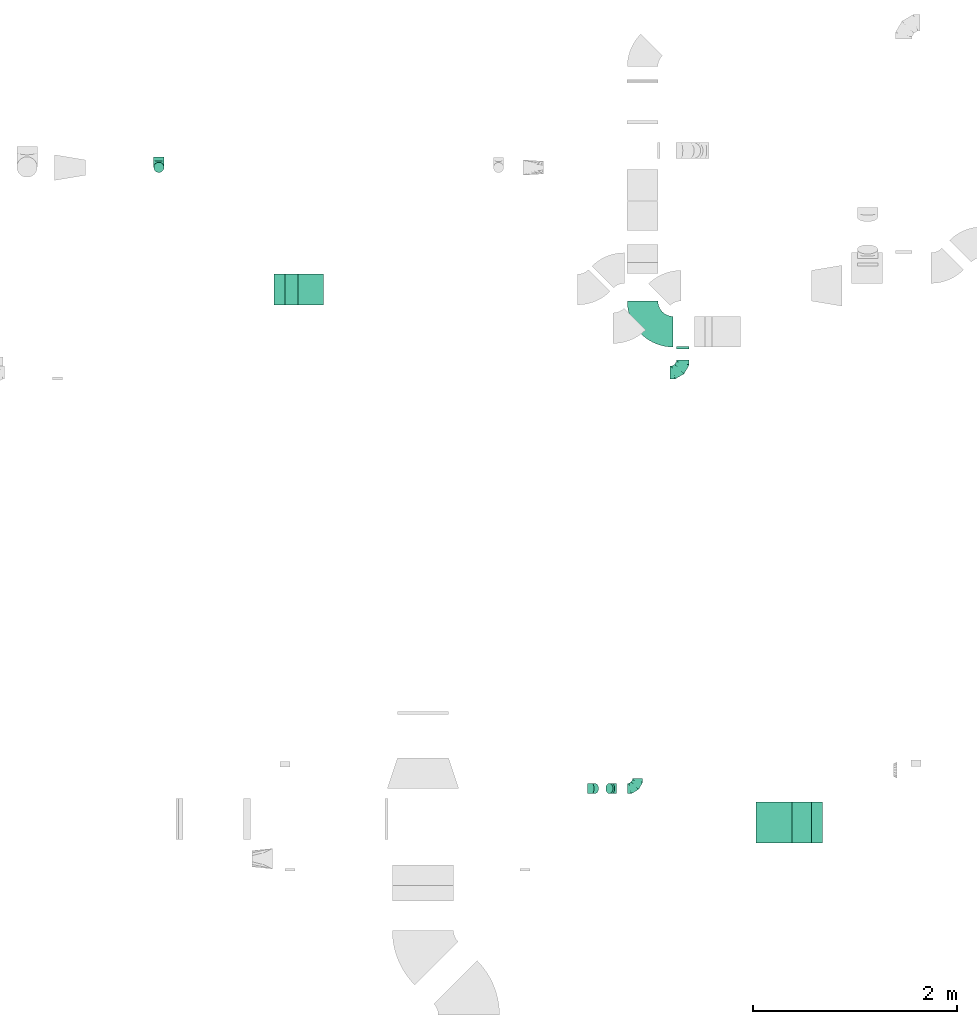
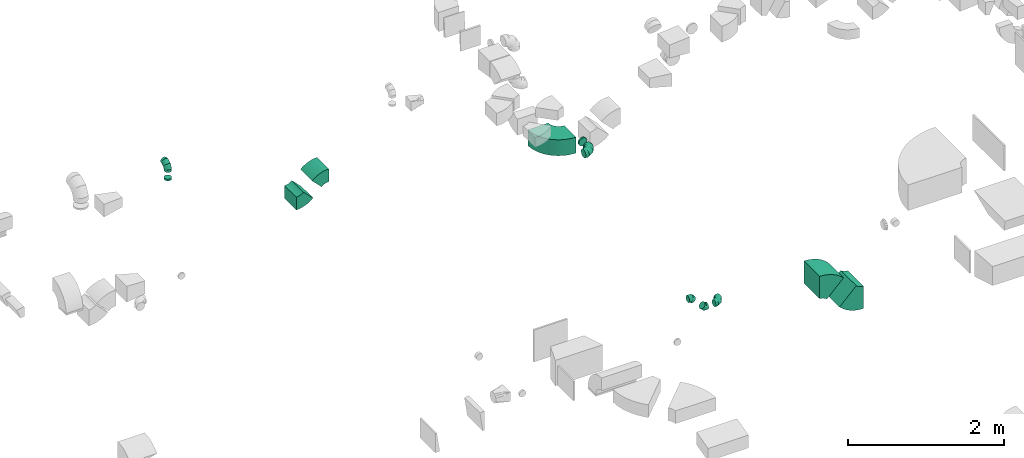
# One storey, part 22 of 44: 12 flow fittings.
"""IFC2X3 building model written with IfcOpenShell, lengths in millimetres."""

from ifc_helpers import new_model, entity, si_unit, converted_unit, derived_unit, direction, frame, frame_2d, origin, place, context, subcontext, project, spatial, polyline, circle_curve, parameter, trimmed, segment, composite_curve, outline, extrude, faceted_brep, source, transform, mapped, material, type_object, type_shapes, element, save


model = new_model("IFC2X3")

# Units and contexts
model_context = context("Model", 3, precision=0.01, world=origin(), true_north=direction((6.12303176911189e-17, 1.0)))
body_context = subcontext(model_context, "Body", "Model", "MODEL_VIEW")
ifc_project = project(units=[si_unit("LENGTHUNIT", "METRE", prefix="MILLI"), si_unit("AREAUNIT", "SQUARE_METRE"), si_unit("VOLUMEUNIT", "CUBIC_METRE"), converted_unit("PLANEANGLEUNIT", "DEGREE", entity("IfcRatioMeasure", 0.0174532925199433), si_unit("PLANEANGLEUNIT", "RADIAN"), dimensions=[0, 0, 0, 0, 0, 0, 0]), si_unit("MASSUNIT", "GRAM", prefix="KILO"), derived_unit("MASSDENSITYUNIT", [(si_unit("MASSUNIT", "GRAM", prefix="KILO"), 1), (si_unit("LENGTHUNIT", "METRE"), -3)]), derived_unit("MOMENTOFINERTIAUNIT", [(si_unit("LENGTHUNIT", "METRE"), 4)]), si_unit("TIMEUNIT", "SECOND"), si_unit("FREQUENCYUNIT", "HERTZ"), si_unit("THERMODYNAMICTEMPERATUREUNIT", "DEGREE_CELSIUS"), derived_unit("THERMALTRANSMITTANCEUNIT", [(si_unit("MASSUNIT", "GRAM", prefix="KILO"), 1), (si_unit("THERMODYNAMICTEMPERATUREUNIT", "KELVIN"), -1), (si_unit("TIMEUNIT", "SECOND"), -3)]), derived_unit("VOLUMETRICFLOWRATEUNIT", [(si_unit("LENGTHUNIT", "METRE"), 3), (si_unit("TIMEUNIT", "SECOND"), -1)]), derived_unit("MASSFLOWRATEUNIT", [(si_unit("MASSUNIT", "GRAM", prefix="KILO"), 1), (si_unit("TIMEUNIT", "SECOND"), -1)]), derived_unit("ROTATIONALFREQUENCYUNIT", [(si_unit("TIMEUNIT", "SECOND"), -1)]), si_unit("ELECTRICCURRENTUNIT", "AMPERE"), si_unit("ELECTRICVOLTAGEUNIT", "VOLT"), si_unit("POWERUNIT", "WATT"), si_unit("FORCEUNIT", "NEWTON", prefix="KILO"), si_unit("ILLUMINANCEUNIT", "LUX"), si_unit("LUMINOUSFLUXUNIT", "LUMEN"), si_unit("LUMINOUSINTENSITYUNIT", "CANDELA"), derived_unit("USERDEFINED", [(si_unit("MASSUNIT", "GRAM", prefix="KILO"), -1), (si_unit("LENGTHUNIT", "METRE"), -2), (si_unit("TIMEUNIT", "SECOND"), 3), (si_unit("LUMINOUSFLUXUNIT", "LUMEN"), 1)]), derived_unit("LINEARVELOCITYUNIT", [(si_unit("LENGTHUNIT", "METRE"), 1), (si_unit("TIMEUNIT", "SECOND"), -1)]), si_unit("PRESSUREUNIT", "PASCAL"), derived_unit("USERDEFINED", [(si_unit("LENGTHUNIT", "METRE"), -2), (si_unit("MASSUNIT", "GRAM", prefix="KILO"), 1), (si_unit("TIMEUNIT", "SECOND"), -2)]), derived_unit("LINEARFORCEUNIT", [(si_unit("MASSUNIT", "GRAM", prefix="KILO"), 1), (si_unit("LENGTHUNIT", "METRE"), 1), (si_unit("TIMEUNIT", "SECOND"), -2), (si_unit("LENGTHUNIT", "METRE"), -1)]), derived_unit("PLANARFORCEUNIT", [(si_unit("MASSUNIT", "GRAM", prefix="KILO"), 1), (si_unit("LENGTHUNIT", "METRE"), 1), (si_unit("TIMEUNIT", "SECOND"), -2), (si_unit("LENGTHUNIT", "METRE"), -2)])], contexts=[model_context])

# Site, building, storey
site_placement = place(None, origin())
site = spatial("IfcSite", under=ifc_project, at=site_placement, CompositionType="ELEMENT")
building_placement = place(site_placement, origin())
building = spatial("IfcBuilding", under=site, at=building_placement, CompositionType="ELEMENT")
storey_placement = place(building_placement, frame((0.0, 0.0, 15900.0)))
storey = spatial("IfcBuildingStorey", under=building, at=storey_placement, CompositionType="ELEMENT", Elevation=15900.0)

# Flow fittings
ifc_material = material()
duct_fitting_type_1 = type_object("IfcDuctFittingType", PredefinedType="NOTDEFINED", material=ifc_material)
shared_shape_1 = source(origin(), body_context, "Body", "Brep", [
    faceted_brep([(-100.0, 0.0, -50.0), (-100.0, -12.94, -48.3), (-100.0, -25.0, -43.3), (-100.0, -35.36, -35.36), (-100.0, -43.3, -25.0), (-100.0, -48.3, -12.94), (-100.0, -50.0, 0.0), (-100.0, -48.3, 12.94), (-100.0, -43.3, 25.0), (-100.0, -35.36, 35.36), (-100.0, -25.0, 43.3), (-100.0, -12.94, 48.3), (-100.0, 0.0, 50.0), (-100.0, 12.94, 48.3), (-100.0, 25.0, 43.3), (-100.0, 35.36, 35.36), (-100.0, 43.3, 25.0), (-100.0, 48.3, 12.94), (-100.0, 50.0, 0.0), (-100.0, 48.3, -12.94), (-100.0, 43.3, -25.0), (-100.0, 35.36, -35.36), (-100.0, 25.0, -43.3), (-100.0, 12.94, -48.3), (-76.67, 12.94, 48.3), (-79.9, 25.0, 43.3), (-73.21, 0.0, 50.0), (-82.68, 35.36, 35.36), (-86.15, 48.3, 12.94), (-86.6, 50.0, 0.0), (-84.81, 43.3, 25.0), (-84.81, 43.3, -25.0), (-82.68, 35.36, -35.36), (-86.15, 48.3, -12.94), (-76.67, 12.94, -48.3), (-73.21, 0.0, -50.0), (-79.9, 25.0, -43.3), (-69.74, -12.94, -48.3), (-66.51, -25.0, -43.3), (-63.73, -35.36, -35.36), (-61.6, -43.3, -25.0), (-60.26, -48.3, -12.94), (-59.81, -50.0, 0.0), (-60.26, -48.3, 12.94), (-61.6, -43.3, 25.0), (-63.73, -35.36, 35.36), (-66.51, -25.0, 43.3), (-69.74, -12.94, 48.3), (-36.27, 36.27, 48.3), (-45.1, 45.1, 43.3), (-26.79, 26.79, 50.0), (-52.68, 52.68, 35.36), (-58.49, 58.49, 25.0), (-62.15, 62.15, 12.94), (-63.4, 63.4, 0.0), (-62.15, 62.15, -12.94), (-58.49, 58.49, -25.0), (-52.68, 52.68, -35.36), (-36.27, 36.27, -48.3), (-26.79, 26.79, -50.0), (-45.1, 45.1, -43.3), (-17.32, 17.32, -48.3), (-8.49, 8.49, -43.3), (-0.91, 0.91, -35.36), (4.9, -4.9, -25.0), (8.56, -8.56, -12.94), (9.81, -9.81, 0.0), (8.56, -8.56, 12.94), (4.9, -4.9, 25.0), (-0.91, 0.91, 35.36), (-8.49, 8.49, 43.3), (-17.32, 17.32, 48.3), (-12.94, 76.67, 48.3), (-25.0, 79.9, 43.3), (0.0, 73.21, 50.0), (-35.36, 82.68, 35.36), (-43.3, 84.81, 25.0), (-48.3, 86.15, 12.94), (-50.0, 86.6, 0.0), (-48.3, 86.15, -12.94), (-43.3, 84.81, -25.0), (-35.36, 82.68, -35.36), (-12.94, 76.67, -48.3), (0.0, 73.21, -50.0), (-25.0, 79.9, -43.3), (12.94, 69.74, -48.3), (25.0, 66.51, -43.3), (35.36, 63.73, -35.36), (43.3, 61.6, -25.0), (48.3, 60.26, -12.94), (50.0, 59.81, 0.0), (48.3, 60.26, 12.94), (43.3, 61.6, 25.0), (35.36, 63.73, 35.36), (25.0, 66.51, 43.3), (12.94, 69.74, 48.3), (-12.94, 100.0, -48.3), (-25.0, 100.0, -43.3), (-35.36, 100.0, -35.36), (-43.3, 100.0, -25.0), (-48.3, 100.0, -12.94), (-50.0, 100.0, 0.0), (-48.3, 100.0, 12.94), (-43.3, 100.0, 25.0), (-35.36, 100.0, 35.36), (-25.0, 100.0, 43.3), (-12.94, 100.0, 48.3), (0.0, 100.0, 50.0), (12.94, 100.0, 48.3), (25.0, 100.0, 43.3), (35.36, 100.0, 35.36), (43.3, 100.0, 25.0), (48.3, 100.0, 12.94), (50.0, 100.0, 0.0), (48.3, 100.0, -12.94), (43.3, 100.0, -25.0), (35.36, 100.0, -35.36), (25.0, 100.0, -43.3), (12.94, 100.0, -48.3), (0.0, 100.0, -50.0)], [[[0, 1, 2, 3, 4, 5, 6, 7, 8, 9, 10, 11, 12, 13, 14, 15, 16, 17, 18, 19, 20, 21, 22, 23]], [[24, 25, 14, 13]], [[26, 24, 13, 12]], [[14, 25, 27, 15]], [[28, 29, 18, 17]], [[30, 28, 17, 16]], [[15, 27, 30, 16]], [[20, 31, 32, 21]], [[33, 31, 20, 19]], [[18, 29, 33, 19]], [[34, 35, 0, 23]], [[36, 34, 23, 22]], [[32, 36, 22, 21]], [[2, 1, 37, 38]], [[3, 2, 38, 39]], [[0, 35, 37, 1]], [[5, 4, 40, 41]], [[6, 5, 41, 42]], [[3, 39, 40, 4]], [[6, 42, 43, 7]], [[7, 43, 44, 8]], [[8, 44, 45, 9]], [[10, 46, 47, 11]], [[11, 47, 26, 12]], [[10, 9, 45, 46]], [[48, 49, 25, 24]], [[50, 48, 24, 26]], [[27, 25, 49, 51]], [[52, 53, 28, 30]], [[51, 52, 30, 27]], [[29, 28, 53, 54]], [[55, 56, 31, 33]], [[54, 55, 33, 29]], [[57, 32, 31, 56]], [[58, 59, 35, 34]], [[60, 58, 34, 36]], [[57, 60, 36, 32]], [[37, 35, 59, 61]], [[38, 37, 61, 62]], [[39, 38, 62, 63]], [[41, 40, 64, 65]], [[42, 41, 65, 66]], [[63, 64, 40, 39]], [[43, 42, 66, 67]], [[44, 43, 67, 68]], [[68, 69, 45, 44]], [[46, 45, 69, 70]], [[47, 46, 70, 71]], [[26, 47, 71, 50]], [[72, 73, 49, 48]], [[74, 72, 48, 50]], [[51, 49, 73, 75]], [[76, 77, 53, 52]], [[75, 76, 52, 51]], [[54, 53, 77, 78]], [[79, 80, 56, 55]], [[78, 79, 55, 54]], [[81, 57, 56, 80]], [[82, 83, 59, 58]], [[84, 82, 58, 60]], [[81, 84, 60, 57]], [[61, 59, 83, 85]], [[62, 61, 85, 86]], [[63, 62, 86, 87]], [[65, 64, 88, 89]], [[66, 65, 89, 90]], [[87, 88, 64, 63]], [[67, 66, 90, 91]], [[68, 67, 91, 92]], [[92, 93, 69, 68]], [[70, 69, 93, 94]], [[71, 70, 94, 95]], [[50, 71, 95, 74]], [[96, 97, 98, 99, 100, 101, 102, 103, 104, 105, 106, 107, 108, 109, 110, 111, 112, 113, 114, 115, 116, 117, 118, 119]], [[72, 74, 107, 106]], [[73, 72, 106, 105]], [[75, 73, 105, 104]], [[77, 76, 103, 102]], [[78, 77, 102, 101]], [[75, 104, 103, 76]], [[78, 101, 100, 79]], [[79, 100, 99, 80]], [[80, 99, 98, 81]], [[96, 119, 83, 82]], [[97, 96, 82, 84]], [[84, 81, 98, 97]], [[83, 119, 118, 85]], [[85, 118, 117, 86]], [[86, 117, 116, 87]], [[88, 115, 114, 89]], [[89, 114, 113, 90]], [[87, 116, 115, 88]], [[91, 90, 113, 112]], [[92, 91, 112, 111]], [[93, 92, 111, 110]], [[95, 94, 109, 108]], [[74, 95, 108, 107]], [[110, 109, 94, 93]]]),
])
type_shapes(duct_fitting_type_1, [shared_shape_1])
flow_fitting_1_placement = place(storey_placement, frame((42036.88, 16133.48, 3250.0), z_axis=(1.0, 0.0, 0.0), x_axis=(0.0, -1.0, 0.0)))
element("IfcFlowFitting", 1, at=flow_fitting_1_placement, inside=storey, type_object=duct_fitting_type_1, material=ifc_material, context=body_context, shape_type="MappedRepresentation", body=[
    mapped(shared_shape_1, transform((0.0, 0.0, 0.0), scale=1.0)),
])
flow_fitting_2_placement = place(storey_placement, frame((46719.69, 10057.12, 3150.0)))
element("IfcFlowFitting", 2, at=flow_fitting_2_placement, inside=storey, type_object=duct_fitting_type_1, material=ifc_material, context=body_context, shape_type="MappedRepresentation", body=[
    mapped(shared_shape_1, transform((0.0, 0.0, 0.0), scale=1.0)),
])
duct_fitting_type_2 = type_object("IfcDuctFittingType", PredefinedType="NOTDEFINED", material=ifc_material)
shared_shape_2 = source(origin(), body_context, "Body", "Brep", [
    faceted_brep([(-125.0, 0.0, -62.5), (-125.0, -16.18, -60.37), (-125.0, -31.25, -54.13), (-125.0, -44.19, -44.19), (-125.0, -54.13, -31.25), (-125.0, -60.37, -16.18), (-125.0, -62.5, 0.0), (-125.0, -60.37, 16.18), (-125.0, -54.13, 31.25), (-125.0, -44.19, 44.19), (-125.0, -31.25, 54.13), (-125.0, -16.18, 60.37), (-125.0, 0.0, 62.5), (-125.0, 16.18, 60.37), (-125.0, 31.25, 54.13), (-125.0, 44.19, 44.19), (-125.0, 54.13, 31.25), (-125.0, 60.37, 16.18), (-125.0, 62.5, 0.0), (-125.0, 60.37, -16.18), (-125.0, 54.13, -31.25), (-125.0, 44.19, -44.19), (-125.0, 31.25, -54.13), (-125.0, 16.18, -60.37), (-95.84, 16.18, 60.37), (-99.88, 31.25, 54.13), (-91.51, 0.0, 62.5), (-103.35, 44.19, 44.19), (-107.68, 60.37, 16.18), (-108.25, 62.5, 0.0), (-106.01, 54.13, 31.25), (-106.01, 54.13, -31.25), (-103.35, 44.19, -44.19), (-107.68, 60.37, -16.18), (-95.84, 16.18, -60.37), (-91.51, 0.0, -62.5), (-99.88, 31.25, -54.13), (-87.17, -16.18, -60.37), (-83.13, -31.25, -54.13), (-79.66, -44.19, -44.19), (-77.0, -54.13, -31.25), (-75.33, -60.37, -16.18), (-74.76, -62.5, 0.0), (-75.33, -60.37, 16.18), (-77.0, -54.13, 31.25), (-79.66, -44.19, 44.19), (-83.13, -31.25, 54.13), (-87.17, -16.18, 60.37), (-45.34, 45.34, 60.37), (-56.37, 56.37, 54.13), (-33.49, 33.49, 62.5), (-65.85, 65.85, 44.19), (-73.12, 73.12, 31.25), (-77.69, 77.69, 16.18), (-79.25, 79.25, 0.0), (-77.69, 77.69, -16.18), (-73.12, 73.12, -31.25), (-65.85, 65.85, -44.19), (-45.34, 45.34, -60.37), (-33.49, 33.49, -62.5), (-56.37, 56.37, -54.13), (-21.65, 21.65, -60.37), (-10.62, 10.62, -54.13), (-1.14, 1.14, -44.19), (6.13, -6.13, -31.25), (10.7, -10.7, -16.18), (12.26, -12.26, 0.0), (10.7, -10.7, 16.18), (6.13, -6.13, 31.25), (-1.14, 1.14, 44.19), (-10.62, 10.62, 54.13), (-21.65, 21.65, 60.37), (-16.18, 95.84, 60.37), (-31.25, 99.88, 54.13), (0.0, 91.51, 62.5), (-44.19, 103.35, 44.19), (-54.13, 106.01, 31.25), (-60.37, 107.68, 16.18), (-62.5, 108.25, 0.0), (-60.37, 107.68, -16.18), (-54.13, 106.01, -31.25), (-44.19, 103.35, -44.19), (-16.18, 95.84, -60.37), (0.0, 91.51, -62.5), (-31.25, 99.88, -54.13), (16.18, 87.17, -60.37), (31.25, 83.13, -54.13), (44.19, 79.66, -44.19), (54.13, 77.0, -31.25), (60.37, 75.33, -16.18), (62.5, 74.76, 0.0), (60.37, 75.33, 16.18), (54.13, 77.0, 31.25), (44.19, 79.66, 44.19), (31.25, 83.13, 54.13), (16.18, 87.17, 60.37), (-16.18, 125.0, -60.37), (-31.25, 125.0, -54.13), (-44.19, 125.0, -44.19), (-54.13, 125.0, -31.25), (-60.37, 125.0, -16.18), (-62.5, 125.0, 0.0), (-60.37, 125.0, 16.18), (-54.13, 125.0, 31.25), (-44.19, 125.0, 44.19), (-31.25, 125.0, 54.13), (-16.18, 125.0, 60.37), (0.0, 125.0, 62.5), (16.18, 125.0, 60.37), (31.25, 125.0, 54.13), (44.19, 125.0, 44.19), (54.13, 125.0, 31.25), (60.37, 125.0, 16.18), (62.5, 125.0, 0.0), (60.37, 125.0, -16.18), (54.13, 125.0, -31.25), (44.19, 125.0, -44.19), (31.25, 125.0, -54.13), (16.18, 125.0, -60.37), (0.0, 125.0, -62.5)], [[[0, 1, 2, 3, 4, 5, 6, 7, 8, 9, 10, 11, 12, 13, 14, 15, 16, 17, 18, 19, 20, 21, 22, 23]], [[24, 25, 14, 13]], [[26, 24, 13, 12]], [[14, 25, 27, 15]], [[28, 29, 18, 17]], [[30, 28, 17, 16]], [[15, 27, 30, 16]], [[20, 31, 32, 21]], [[33, 31, 20, 19]], [[18, 29, 33, 19]], [[34, 35, 0, 23]], [[36, 34, 23, 22]], [[21, 32, 36, 22]], [[1, 0, 35, 37]], [[2, 1, 37, 38]], [[38, 39, 3, 2]], [[5, 4, 40, 41]], [[6, 5, 41, 42]], [[39, 40, 4, 3]], [[6, 42, 43, 7]], [[7, 43, 44, 8]], [[45, 9, 8, 44]], [[9, 45, 46, 10]], [[10, 46, 47, 11]], [[26, 12, 11, 47]], [[48, 49, 25, 24]], [[50, 48, 24, 26]], [[27, 25, 49, 51]], [[52, 53, 28, 30]], [[51, 52, 30, 27]], [[29, 28, 53, 54]], [[55, 56, 31, 33]], [[54, 55, 33, 29]], [[57, 32, 31, 56]], [[58, 59, 35, 34]], [[60, 58, 34, 36]], [[57, 60, 36, 32]], [[37, 35, 59, 61]], [[38, 37, 61, 62]], [[39, 38, 62, 63]], [[41, 40, 64, 65]], [[42, 41, 65, 66]], [[63, 64, 40, 39]], [[43, 42, 66, 67]], [[44, 43, 67, 68]], [[68, 69, 45, 44]], [[46, 45, 69, 70]], [[47, 46, 70, 71]], [[26, 47, 71, 50]], [[72, 73, 49, 48]], [[74, 72, 48, 50]], [[51, 49, 73, 75]], [[76, 77, 53, 52]], [[75, 76, 52, 51]], [[54, 53, 77, 78]], [[79, 80, 56, 55]], [[78, 79, 55, 54]], [[81, 57, 56, 80]], [[82, 83, 59, 58]], [[84, 82, 58, 60]], [[81, 84, 60, 57]], [[61, 59, 83, 85]], [[62, 61, 85, 86]], [[63, 62, 86, 87]], [[65, 64, 88, 89]], [[66, 65, 89, 90]], [[87, 88, 64, 63]], [[67, 66, 90, 91]], [[68, 67, 91, 92]], [[92, 93, 69, 68]], [[70, 69, 93, 94]], [[71, 70, 94, 95]], [[50, 71, 95, 74]], [[96, 97, 98, 99, 100, 101, 102, 103, 104, 105, 106, 107, 108, 109, 110, 111, 112, 113, 114, 115, 116, 117, 118, 119]], [[72, 74, 107, 106]], [[73, 72, 106, 105]], [[75, 73, 105, 104]], [[77, 76, 103, 102]], [[78, 77, 102, 101]], [[75, 104, 103, 76]], [[78, 101, 100, 79]], [[79, 100, 99, 80]], [[80, 99, 98, 81]], [[96, 119, 83, 82]], [[97, 96, 82, 84]], [[84, 81, 98, 97]], [[83, 119, 118, 85]], [[85, 118, 117, 86]], [[116, 87, 86, 117]], [[88, 115, 114, 89]], [[89, 114, 113, 90]], [[115, 88, 87, 116]], [[91, 90, 113, 112]], [[92, 91, 112, 111]], [[111, 110, 93, 92]], [[95, 94, 109, 108]], [[74, 95, 108, 107]], [[110, 109, 94, 93]]]),
])
type_shapes(duct_fitting_type_2, [shared_shape_2])
flow_fitting_3_placement = place(storey_placement, frame((47162.38, 14126.04, 2880.0)))
element("IfcFlowFitting", 3, at=flow_fitting_3_placement, inside=storey, type_object=duct_fitting_type_2, material=ifc_material, context=body_context, shape_type="MappedRepresentation", body=[
    mapped(shared_shape_2, transform((0.0, 0.0, 0.0), scale=1.0)),
])
duct_fitting_type_3 = type_object("IfcDuctFittingType", PredefinedType="NOTDEFINED", material=ifc_material)
shared_shape_3 = source(origin(), body_context, "Body", "Brep", [
    faceted_brep([(-41.42, 0.0, -50.0), (-41.42, -12.94, -48.3), (-41.42, -25.0, -43.3), (-41.42, -35.36, -35.36), (-41.42, -43.3, -25.0), (-41.42, -48.3, -12.94), (-41.42, -50.0, 0.0), (-41.42, -48.3, 12.94), (-41.42, -43.3, 25.0), (-41.42, -35.36, 35.36), (-41.42, -25.0, 43.3), (-41.42, -12.94, 48.3), (-41.42, 0.0, 50.0), (-41.42, 12.94, 48.3), (-41.42, 25.0, 43.3), (-41.42, 35.36, 35.36), (-41.42, 43.3, 25.0), (-41.42, 48.3, 12.94), (-41.42, 50.0, 0.0), (-41.42, 48.3, -12.94), (-41.42, 43.3, -25.0), (-41.42, 35.36, -35.36), (-41.42, 25.0, -43.3), (-41.42, 12.94, -48.3), (-5.36, 12.94, 48.3), (-10.36, 25.0, 43.3), (0.0, 0.0, 50.0), (-14.64, 35.36, 35.36), (-20.0, 48.3, 12.94), (-20.71, 50.0, 0.0), (-17.94, 43.3, 25.0), (-17.94, 43.3, -25.0), (-14.64, 35.36, -35.36), (-20.0, 48.3, -12.94), (-5.36, 12.94, -48.3), (0.0, 0.0, -50.0), (-10.36, 25.0, -43.3), (5.36, -12.94, -48.3), (10.36, -25.0, -43.3), (14.64, -35.36, -35.36), (17.94, -43.3, -25.0), (20.0, -48.3, -12.94), (20.71, -50.0, 0.0), (20.0, -48.3, 12.94), (17.94, -43.3, 25.0), (14.64, -35.36, 35.36), (10.36, -25.0, 43.3), (5.36, -12.94, 48.3), (29.29, 29.29, 50.0), (20.14, 38.44, 48.3), (11.61, 46.97, 43.3), (4.29, 54.29, 35.36), (-1.33, 59.91, 25.0), (-4.86, 63.44, 12.94), (-6.07, 64.64, 0.0), (-4.86, 63.44, -12.94), (-1.33, 59.91, -25.0), (4.29, 54.29, -35.36), (11.61, 46.97, -43.3), (20.14, 38.44, -48.3), (29.29, 29.29, -50.0), (38.44, 20.14, -48.3), (46.97, 11.61, -43.3), (54.29, 4.29, -35.36), (59.91, -1.33, -25.0), (63.44, -4.86, -12.94), (64.64, -6.07, 0.0), (63.44, -4.86, 12.94), (59.91, -1.33, 25.0), (54.29, 4.29, 35.36), (46.97, 11.61, 43.3), (38.44, 20.14, 48.3)], [[[0, 1, 2, 3, 4, 5, 6, 7, 8, 9, 10, 11, 12, 13, 14, 15, 16, 17, 18, 19, 20, 21, 22, 23]], [[24, 25, 14, 13]], [[26, 24, 13, 12]], [[14, 25, 27, 15]], [[28, 29, 18, 17]], [[30, 28, 17, 16]], [[16, 15, 27, 30]], [[20, 31, 32, 21]], [[33, 31, 20, 19]], [[18, 29, 33, 19]], [[34, 35, 0, 23]], [[36, 34, 23, 22]], [[32, 36, 22, 21]], [[1, 0, 35, 37]], [[2, 1, 37, 38]], [[38, 39, 3, 2]], [[5, 4, 40, 41]], [[6, 5, 41, 42]], [[39, 40, 4, 3]], [[6, 42, 43, 7]], [[7, 43, 44, 8]], [[8, 44, 45, 9]], [[9, 45, 46, 10]], [[10, 46, 47, 11]], [[26, 12, 11, 47]], [[24, 26, 48, 49]], [[25, 24, 49, 50]], [[27, 25, 50, 51]], [[28, 30, 52, 53]], [[29, 28, 53, 54]], [[27, 51, 52, 30]], [[29, 54, 55, 33]], [[33, 55, 56, 31]], [[31, 56, 57, 32]], [[36, 58, 59, 34]], [[34, 59, 60, 35]], [[36, 32, 57, 58]], [[61, 62, 38, 37]], [[60, 61, 37, 35]], [[63, 39, 38, 62]], [[40, 64, 65, 41]], [[41, 65, 66, 42]], [[64, 40, 39, 63]], [[43, 42, 66, 67]], [[44, 43, 67, 68]], [[68, 69, 45, 44]], [[47, 46, 70, 71]], [[26, 47, 71, 48]], [[69, 70, 46, 45]], [[59, 58, 57, 56, 55, 54, 53, 52, 51, 50, 49, 48, 71, 70, 69, 68, 67, 66, 65, 64, 63, 62, 61, 60]]]),
])
type_shapes(duct_fitting_type_3, [shared_shape_3])
for number, where, z_axis, x_axis in (
    (4, (46473.97, 10057.12, 3150.0), (0.0, 1.0, 0.0), (-1.0, 0.0, 0.0)),
    (5, (46273.97, 10057.12, 3350.0), (0.0, -1.0, 0.0), (-0.707106781186503, 0.0, 0.707106781186592)),
):
    element("IfcFlowFitting", number, at=place(storey_placement, frame(where, z_axis=z_axis, x_axis=x_axis)), inside=storey, type_object=duct_fitting_type_3, material=ifc_material, context=body_context, shape_type="MappedRepresentation", body=[
        mapped(shared_shape_3, transform((0.0, 0.0, 0.0), scale=1.0)),
    ])
duct_fitting_type_4 = type_object("IfcDuctFittingType", PredefinedType="NOTDEFINED", material=ifc_material)
shared_shape_4 = source(origin(), body_context, "Body", "Brep", [
    faceted_brep([(20.0, 16.18, -60.37), (20.0, 31.25, -54.13), (20.0, 44.19, -44.19), (20.0, 54.13, -31.25), (20.0, 60.37, -16.18), (20.0, 62.5, 0.0), (20.0, 60.37, 16.18), (20.0, 54.13, 31.25), (20.0, 44.19, 44.19), (20.0, 31.25, 54.13), (20.0, 16.18, 60.37), (20.0, 0.0, 62.5), (20.0, -16.18, 60.37), (20.0, -31.25, 54.13), (20.0, -44.19, 44.19), (20.0, -54.13, 31.25), (20.0, -60.37, 16.18), (20.0, -62.5, 0.0), (20.0, -60.37, -16.18), (20.0, -54.13, -31.25), (20.0, -44.19, -44.19), (20.0, -31.25, -54.13), (20.0, -16.18, -60.37), (20.0, 0.0, -62.5), (0.0, 0.0, 62.5), (0.0, 16.18, 60.37), (-6.1, 16.18, 60.37), (-6.1, 0.0, 62.5), (0.0, 31.25, 54.13), (-6.1, 31.25, 54.13), (0.0, 44.19, 44.19), (-6.1, 44.19, 44.19), (0.0, 54.13, 31.25), (0.0, 60.37, 16.18), (-6.1, 60.37, 16.18), (-6.1, 54.13, 31.25), (0.0, 62.5, 0.0), (-6.1, 62.5, 0.0), (0.0, 60.37, -16.18), (-6.1, 60.37, -16.18), (0.0, 54.13, -31.25), (-6.1, 54.13, -31.25), (0.0, 44.19, -44.19), (-6.1, 44.19, -44.19), (0.0, 31.25, -54.13), (0.0, 16.18, -60.37), (-6.1, 16.18, -60.37), (-6.1, 31.25, -54.13), (0.0, 0.0, -62.5), (-6.1, 0.0, -62.5), (0.0, -16.18, -60.37), (-6.1, -16.18, -60.37), (0.0, -31.25, -54.13), (-6.1, -31.25, -54.13), (0.0, -44.19, -44.19), (-6.1, -44.19, -44.19), (0.0, -54.13, -31.25), (0.0, -60.37, -16.18), (-6.1, -60.37, -16.18), (-6.1, -54.13, -31.25), (0.0, -62.5, 0.0), (-6.1, -62.5, 0.0), (0.0, -60.37, 16.18), (-6.1, -60.37, 16.18), (0.0, -54.13, 31.25), (-6.1, -54.13, 31.25), (0.0, -44.19, 44.19), (-6.1, -44.19, 44.19), (0.0, -31.25, 54.13), (0.0, -16.18, 60.37), (-6.1, -16.18, 60.37), (-6.1, -31.25, 54.13)], [[[0, 1, 2, 3, 4, 5, 6, 7, 8, 9, 10, 11, 12, 13, 14, 15, 16, 17, 18, 19, 20, 21, 22, 23]], [[24, 11, 10, 25, 26, 27]], [[25, 10, 9, 28, 29, 26]], [[28, 9, 8, 30, 31, 29]], [[32, 7, 6, 33, 34, 35]], [[33, 6, 5, 36, 37, 34]], [[30, 8, 7, 32, 35, 31]], [[36, 5, 4, 38, 39, 37]], [[38, 4, 3, 40, 41, 39]], [[40, 3, 2, 42, 43, 41]], [[44, 1, 0, 45, 46, 47]], [[45, 0, 23, 48, 49, 46]], [[42, 2, 1, 44, 47, 43]], [[48, 23, 22, 50, 51, 49]], [[50, 22, 21, 52, 53, 51]], [[52, 21, 20, 54, 55, 53]], [[56, 19, 18, 57, 58, 59]], [[57, 18, 17, 60, 61, 58]], [[54, 20, 19, 56, 59, 55]], [[60, 17, 16, 62, 63, 61]], [[62, 16, 15, 64, 65, 63]], [[64, 15, 14, 66, 67, 65]], [[68, 13, 12, 69, 70, 71]], [[69, 12, 11, 24, 27, 70]], [[66, 14, 13, 68, 71, 67]], [[49, 51, 53, 55, 59, 58, 61, 63, 65, 67, 71, 70, 27, 26, 29, 31, 35, 34, 37, 39, 41, 43, 47, 46]]]),
])
type_shapes(duct_fitting_type_4, [shared_shape_4])
flow_fitting_4_placement = place(storey_placement, frame((47162.38, 14375.32, 2880.0), z_axis=(0.0, 0.0, -1.0), x_axis=(0.0, -1.0, 0.0)))
element("IfcFlowFitting", 6, at=flow_fitting_4_placement, inside=storey, type_object=duct_fitting_type_4, material=ifc_material, context=body_context, shape_type="MappedRepresentation", body=[
    mapped(shared_shape_4, transform((0.0, 0.0, 0.0), scale=1.0)),
])
duct_fitting_type_5 = type_object("IfcDuctFittingType", PredefinedType="NOTDEFINED", material=ifc_material)
shared_shape_5 = source(origin(), body_context, "Body", "Brep", [
    faceted_brep([(20.0, 12.94, -48.3), (20.0, 25.0, -43.3), (20.0, 35.36, -35.36), (20.0, 43.3, -25.0), (20.0, 48.3, -12.94), (20.0, 50.0, 0.0), (20.0, 48.3, 12.94), (20.0, 43.3, 25.0), (20.0, 35.36, 35.36), (20.0, 25.0, 43.3), (20.0, 12.94, 48.3), (20.0, 0.0, 50.0), (20.0, -12.94, 48.3), (20.0, -25.0, 43.3), (20.0, -35.36, 35.36), (20.0, -43.3, 25.0), (20.0, -48.3, 12.94), (20.0, -50.0, 0.0), (20.0, -48.3, -12.94), (20.0, -43.3, -25.0), (20.0, -35.36, -35.36), (20.0, -25.0, -43.3), (20.0, -12.94, -48.3), (20.0, 0.0, -50.0), (0.0, 0.0, 50.0), (0.0, 12.94, 48.3), (-6.1, 12.94, 48.3), (-6.1, 0.0, 50.0), (0.0, 25.0, 43.3), (-6.1, 25.0, 43.3), (0.0, 35.36, 35.36), (-6.1, 35.36, 35.36), (0.0, 43.3, 25.0), (0.0, 48.3, 12.94), (-6.1, 48.3, 12.94), (-6.1, 43.3, 25.0), (0.0, 50.0, 0.0), (-6.1, 50.0, 0.0), (0.0, 48.3, -12.94), (-6.1, 48.3, -12.94), (0.0, 43.3, -25.0), (-6.1, 43.3, -25.0), (0.0, 35.36, -35.36), (-6.1, 35.36, -35.36), (0.0, 25.0, -43.3), (0.0, 12.94, -48.3), (-6.1, 12.94, -48.3), (-6.1, 25.0, -43.3), (0.0, 0.0, -50.0), (-6.1, 0.0, -50.0), (0.0, -12.94, -48.3), (-6.1, -12.94, -48.3), (0.0, -25.0, -43.3), (-6.1, -25.0, -43.3), (0.0, -35.36, -35.36), (-6.1, -35.36, -35.36), (0.0, -43.3, -25.0), (0.0, -48.3, -12.94), (-6.1, -48.3, -12.94), (-6.1, -43.3, -25.0), (0.0, -50.0, 0.0), (-6.1, -50.0, 0.0), (0.0, -48.3, 12.94), (-6.1, -48.3, 12.94), (0.0, -43.3, 25.0), (-6.1, -43.3, 25.0), (0.0, -35.36, 35.36), (-6.1, -35.36, 35.36), (0.0, -25.0, 43.3), (0.0, -12.94, 48.3), (-6.1, -12.94, 48.3), (-6.1, -25.0, 43.3)], [[[0, 1, 2, 3, 4, 5, 6, 7, 8, 9, 10, 11, 12, 13, 14, 15, 16, 17, 18, 19, 20, 21, 22, 23]], [[24, 11, 10, 25, 26, 27]], [[25, 10, 9, 28, 29, 26]], [[28, 9, 8, 30, 31, 29]], [[32, 7, 6, 33, 34, 35]], [[33, 6, 5, 36, 37, 34]], [[30, 8, 7, 32, 35, 31]], [[36, 5, 4, 38, 39, 37]], [[38, 4, 3, 40, 41, 39]], [[40, 3, 2, 42, 43, 41]], [[44, 1, 0, 45, 46, 47]], [[45, 0, 23, 48, 49, 46]], [[42, 2, 1, 44, 47, 43]], [[48, 23, 22, 50, 51, 49]], [[50, 22, 21, 52, 53, 51]], [[52, 21, 20, 54, 55, 53]], [[56, 19, 18, 57, 58, 59]], [[57, 18, 17, 60, 61, 58]], [[54, 20, 19, 56, 59, 55]], [[60, 17, 16, 62, 63, 61]], [[62, 16, 15, 64, 65, 63]], [[64, 15, 14, 66, 67, 65]], [[68, 13, 12, 69, 70, 71]], [[69, 12, 11, 24, 27, 70]], [[66, 14, 13, 68, 71, 67]], [[49, 51, 53, 55, 59, 58, 61, 63, 65, 67, 71, 70, 27, 26, 29, 31, 35, 34, 37, 39, 41, 43, 47, 46]]]),
])
type_shapes(duct_fitting_type_5, [shared_shape_5])
flow_fitting_5_placement = place(storey_placement, frame((42036.88, 16133.48, 3025.0), z_axis=(0.0, -1.0, 0.0), x_axis=(0.0, 0.0, 1.0)))
element("IfcFlowFitting", 7, at=flow_fitting_5_placement, inside=storey, type_object=duct_fitting_type_5, material=ifc_material, context=body_context, shape_type="MappedRepresentation", body=[
    mapped(shared_shape_5, transform((0.0, 0.0, 0.0), scale=1.0)),
])
duct_fitting_type_6 = type_object("IfcDuctFittingType", PredefinedType="NOTDEFINED", material=ifc_material)
shared_shape_6 = source(origin(), body_context, "Body", "SweptSolid", [
    extrude(outline(composite_curve([segment(polyline([(-300.0, -150.0), (0.0, -150.0)]), True, "CONTINUOUS"), segment(trimmed(circle_curve(frame_2d((150.0, -150.0), x_axis=(0.0, 1.0)), 150.0), [parameter(0.0)], [parameter(90.0)], True, "PARAMETER"), False, "CONTINUOUS"), segment(polyline([(150.0, 0.0), (150.0, 300.0)]), True, "CONTINUOUS"), segment(trimmed(circle_curve(frame_2d((150.0, -150.0), x_axis=(0.0, 1.0)), 450.0), [parameter(0.0)], [parameter(90.0000000000001)], True, "PARAMETER"), True, "CONTINUOUS")], self_intersect=False)), frame((-150.0, 150.0, -125.0), z_axis=(0.0, 0.0, 1.0), x_axis=(-1.0, 0.0, 0.0)), (0.0, 0.0, 1.0), 250.0),
])
type_shapes(duct_fitting_type_6, [shared_shape_6])
flow_fitting_6_placement = place(storey_placement, frame((46769.03, 14525.32, 2850.0), z_axis=(0.0, 0.0, 1.0), x_axis=(0.0, -1.0, 0.0)))
element("IfcFlowFitting", 8, at=flow_fitting_6_placement, inside=storey, type_object=duct_fitting_type_6, material=ifc_material, context=body_context, shape_type="MappedRepresentation", body=[
    mapped(shared_shape_6, transform((0.0, 0.0, 0.0), scale=1.0)),
])
duct_fitting_type_7 = type_object("IfcDuctFittingType", PredefinedType="NOTDEFINED", material=ifc_material)
shared_shape_7 = source(origin(), body_context, "Body", "SweptSolid", [
    extrude(outline(composite_curve([segment(polyline([(-136.61, -88.39), (63.39, -88.39)]), True, "CONTINUOUS"), segment(trimmed(circle_curve(frame_2d((213.39, -88.39), x_axis=(-0.707106781186546, 0.707106781186546)), 150.0), [parameter(0.0)], [parameter(45.0)], True, "PARAMETER"), False, "CONTINUOUS"), segment(polyline([(107.32, 17.68), (-34.1, 159.1)]), True, "CONTINUOUS"), segment(trimmed(circle_curve(frame_2d((213.39, -88.39), x_axis=(-0.707106781186546, 0.707106781186546)), 350.0), [parameter(0.0)], [parameter(45.0)], True, "PARAMETER"), True, "CONTINUOUS")], self_intersect=False)), frame((-15.17, 36.61, -150.0), z_axis=(0.0, 0.0, 1.0), x_axis=(-0.707106781186547, 0.707106781186548, 0.0)), (0.0, 0.0, 1.0), 300.0),
])
type_shapes(duct_fitting_type_7, [shared_shape_7])
for number, where, z_axis, x_axis in (
    (9, (43542.16, 14938.36, 3325.02), (0.0, -1.0, 0.0), (-1.0, 0.0, 0.0)),
    (10, (43267.14, 14938.36, 3050.0), (0.0, 1.0, 0.0), (-0.707106781186548, 0.0, -0.707106781186548)),
):
    element("IfcFlowFitting", number, at=place(storey_placement, frame(where, z_axis=z_axis, x_axis=x_axis)), inside=storey, type_object=duct_fitting_type_7, material=ifc_material, context=body_context, shape_type="MappedRepresentation", body=[
        mapped(shared_shape_7, transform((0.0, 0.0, 0.0), scale=1.0)),
    ])
duct_fitting_type_8 = type_object("IfcDuctFittingType", PredefinedType="NOTDEFINED", material=ifc_material)
shared_shape_8 = source(origin(), body_context, "Body", "SweptSolid", [
    extrude(outline(composite_curve([segment(polyline([(-222.6, -114.9), (127.4, -114.9)]), True, "CONTINUOUS"), segment(trimmed(circle_curve(frame_2d((277.4, -114.9), x_axis=(-0.707106781186553, 0.707106781186546)), 150.0), [parameter(0.0)], [parameter(45.0)], True, "PARAMETER"), False, "CONTINUOUS"), segment(polyline([(171.34, -8.84), (-76.15, 238.65)]), True, "CONTINUOUS"), segment(trimmed(circle_curve(frame_2d((277.4, -114.9), x_axis=(-0.707106781186553, 0.707106781186546)), 500.0), [parameter(0.0)], [parameter(45.0)], True, "PARAMETER"), True, "CONTINUOUS")], self_intersect=False)), frame((-19.71, 47.6, -200.0), z_axis=(0.0, 0.0, 1.0), x_axis=(-0.707106781186547, 0.707106781186548, 0.0)), (0.0, 0.0, 1.0), 400.0),
])
type_shapes(duct_fitting_type_8, [shared_shape_8])
for number, where, z_axis, x_axis in (
    (11, (48014.03, 9725.31, 3275.0), (0.0, 1.0, 0.0), (1.0, 0.0, 0.0)),
    (12, (48394.03, 9725.31, 2895.0), (0.0, -1.0, 0.0), (0.707106781186597, 0.0, -0.707106781186498)),
):
    element("IfcFlowFitting", number, at=place(storey_placement, frame(where, z_axis=z_axis, x_axis=x_axis)), inside=storey, type_object=duct_fitting_type_8, material=ifc_material, context=body_context, shape_type="MappedRepresentation", body=[
        mapped(shared_shape_8, transform((0.0, 0.0, 0.0), scale=1.0)),
    ])

save(model, "model.ifc")
